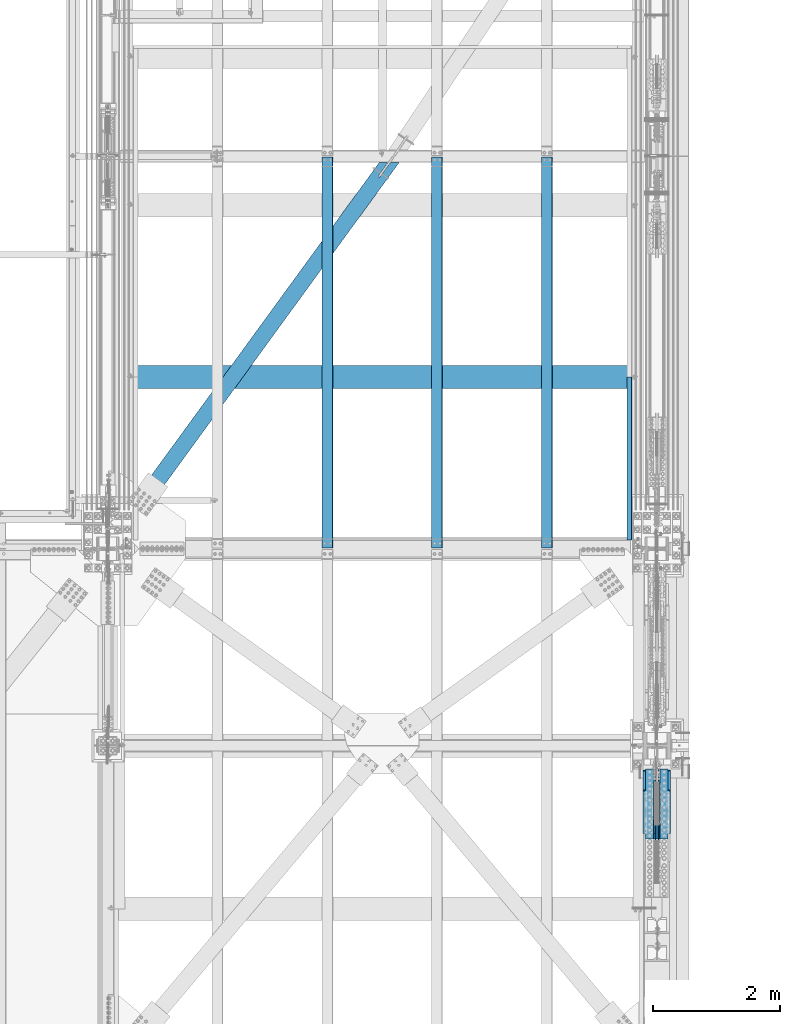
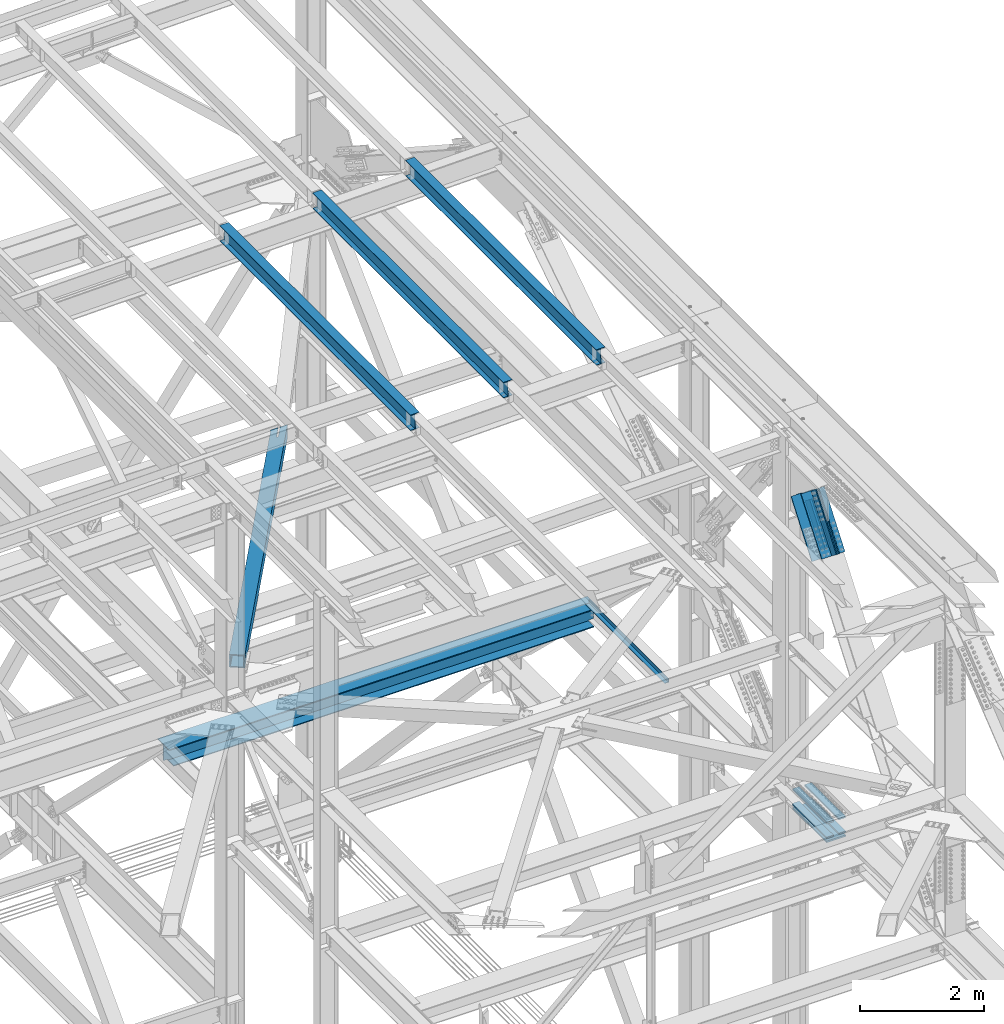
# One storey, part 1989 of 3843: 11 beams, 6 members, 8 elements without a shape of their own.
"""IFC2X3 building model written with IfcOpenShell, lengths in millimetres."""

from ifc_helpers import new_model, si_unit, frame, origin_with_axes, place, context, subcontext, project, spatial, faceted_brep, material, type_object, element, aggregate, save


model = new_model("IFC2X3")

# Units and contexts
model_context = context("Model", 3, precision=1e-05, world=origin_with_axes())
body_context = subcontext(model_context, "Body", "Model", "MODEL_VIEW")
ifc_project = project(units=[si_unit("LENGTHUNIT", "METRE", prefix="MILLI"), si_unit("AREAUNIT", "SQUARE_METRE"), si_unit("VOLUMEUNIT", "CUBIC_METRE"), si_unit("MASSUNIT", "GRAM", prefix="KILO"), si_unit("TIMEUNIT", "SECOND"), si_unit("PLANEANGLEUNIT", "RADIAN"), si_unit("SOLIDANGLEUNIT", "STERADIAN"), si_unit("THERMODYNAMICTEMPERATUREUNIT", "DEGREE_CELSIUS"), si_unit("LUMINOUSINTENSITYUNIT", "LUMEN")], contexts=[model_context])

# Site, building, storey
site_placement = place(None, origin_with_axes())
site = spatial("IfcSite", under=ifc_project, at=site_placement, CompositionType="ELEMENT")
building_placement = place(site_placement, origin_with_axes())
building = spatial("IfcBuilding", under=site, at=building_placement, Name="Undefined", CompositionType="ELEMENT")
storey_placement = place(building_placement, origin_with_axes())
storey = spatial("IfcBuildingStorey", under=building, at=storey_placement, Name="Undefined", CompositionType="ELEMENT", Elevation=0.0)

# Assembly, beam
assembly_1_placement = place(storey_placement, origin_with_axes())
assembly_1 = element("IfcElementAssembly", 1, at=assembly_1_placement, inside=storey, Name="BEAM", AssemblyPlace="NOTDEFINED", PredefinedType="RIGID_FRAME")
ifc_material_1 = material(Name="STEEL/A992")
beam_type_1 = type_object("IfcBeamType", Name="W12X26", PredefinedType="NOTDEFINED")
beam_1_placement = place(assembly_1_placement, frame((80463.9092624381, 92214.7, 46502.5139311718), z_axis=(-0.0211520980073474, 0.0, 0.999776269347241), x_axis=(0.0, 1.0, 0.0)))
beam_1 = element("IfcBeam", 2, at=beam_1_placement, type_object=beam_type_1, material=ifc_material_1, Name="BEAM", ObjectType="W12X26", context=body_context, shape_type="Brep", body=[
    faceted_brep([(12.7000000064072, 82.5500000002939, -155.574999999815), (12.7000000064072, 82.5500000003085, -146.049999999828), (6159.50000000003, 82.5500000003085, -146.049999999836), (6159.50000000003, 82.5500000003085, -155.574999999822), (12.7000000064072, 3.17499999985739, -146.049999999763), (6159.50000000003, 3.17499999985739, -146.049999999777), (12.7000000064072, 3.17500000014843, 146.04999999977), (6159.50000000003, 3.17500000014843, 146.049999999763), (12.7000000064072, 82.5500000005995, 146.049999999697), (6159.50000000003, 82.5500000005995, 146.049999999697), (12.7000000064072, 82.5500000006141, 155.574999999684), (6159.50000000003, 82.5500000005995, 155.574999999677), (12.7000000064072, -82.5500000003231, 155.574999999822), (6159.50000000003, -82.5500000003231, 155.574999999822), (12.7000000064072, -82.5500000003231, 146.049999999836), (6159.50000000003, -82.5500000003231, 146.049999999828), (12.7000000064072, -3.17499999987194, 146.049999999777), (6159.50000000003, -3.17499999987194, 146.049999999763), (12.7000000064072, -3.17500000016298, -146.049999999763), (6159.50000000003, -3.17500000017753, -146.049999999763), (12.7000000064072, -82.5500000006141, -146.04999999969), (6159.50000000003, -82.5500000006286, -146.049999999697), (12.7000000064072, -82.5500000006432, -155.574999999677), (6159.50000000003, -82.5500000006286, -155.574999999677)], [[[0, 1, 2, 3]], [[1, 4, 5, 2]], [[4, 6, 7, 5]], [[6, 8, 9, 7]], [[8, 10, 11, 9]], [[10, 12, 13, 11]], [[12, 14, 15, 13]], [[14, 16, 17, 15]], [[16, 18, 19, 17]], [[18, 20, 21, 19]], [[20, 22, 23, 21]], [[22, 0, 3, 23]], [[5, 7, 9, 11, 13, 15, 17, 19, 21, 23, 3, 2]], [[22, 20, 18, 16, 14, 12, 10, 8, 6, 4, 1, 0]]]),
])
aggregate(assembly_1, [beam_1])

assembly_2_placement = place(storey_placement, origin_with_axes())
assembly_2 = element("IfcElementAssembly", 3, at=assembly_2_placement, inside=storey, Name="BEAM", AssemblyPlace="NOTDEFINED", PredefinedType="RIGID_FRAME")
beam_2_placement = place(assembly_2_placement, frame((83918.3092624381, 92214.7, 46575.5980896944), z_axis=(-0.0211520980073474, 0.0, 0.999776269347241), x_axis=(0.0, 1.0, 0.0)))
beam_2 = element("IfcBeam", 4, at=beam_2_placement, type_object=beam_type_1, material=ifc_material_1, Name="BEAM", ObjectType="W12X26", context=body_context, shape_type="Brep", body=[
    faceted_brep([(12.7000000064072, 82.5500000002939, -155.574999999815), (12.7000000064072, 82.5500000003085, -146.049999999828), (6159.50000000003, 82.5500000003085, -146.049999999836), (6159.50000000003, 82.5500000003085, -155.574999999822), (12.7000000064072, 3.17499999985739, -146.049999999763), (6159.50000000003, 3.17499999985739, -146.049999999777), (12.7000000064072, 3.17500000014843, 146.04999999977), (6159.50000000003, 3.17500000014843, 146.049999999763), (12.7000000064072, 82.5500000005995, 146.049999999697), (6159.50000000003, 82.5500000005995, 146.049999999697), (12.7000000064072, 82.5500000006141, 155.574999999684), (6159.50000000003, 82.5500000005995, 155.574999999677), (12.7000000064072, -82.5500000003231, 155.574999999822), (6159.50000000003, -82.5500000003231, 155.574999999822), (12.7000000064072, -82.5500000003231, 146.049999999836), (6159.50000000003, -82.5500000003231, 146.049999999828), (12.7000000064072, -3.17499999987194, 146.049999999777), (6159.50000000003, -3.17499999987194, 146.049999999763), (12.7000000064072, -3.17500000016298, -146.049999999763), (6159.50000000003, -3.17500000017753, -146.049999999763), (12.7000000064072, -82.5500000006141, -146.04999999969), (6159.50000000003, -82.5500000006286, -146.049999999697), (12.7000000064072, -82.5500000006432, -155.574999999677), (6159.50000000003, -82.5500000006286, -155.574999999677)], [[[0, 1, 2, 3]], [[1, 4, 5, 2]], [[4, 6, 7, 5]], [[6, 8, 9, 7]], [[8, 10, 11, 9]], [[10, 12, 13, 11]], [[12, 14, 15, 13]], [[14, 16, 17, 15]], [[16, 18, 19, 17]], [[18, 20, 21, 19]], [[20, 22, 23, 21]], [[22, 0, 3, 23]], [[5, 7, 9, 11, 13, 15, 17, 19, 21, 23, 3, 2]], [[22, 20, 18, 16, 14, 12, 10, 8, 6, 4, 1, 0]]]),
])
aggregate(assembly_2, [beam_2])

assembly_3_placement = place(storey_placement, origin_with_axes())
assembly_3 = element("IfcElementAssembly", 5, at=assembly_3_placement, inside=storey, Name="BEAM", AssemblyPlace="NOTDEFINED", PredefinedType="RIGID_FRAME")
beam_3_placement = place(assembly_3_placement, frame((82191.1092624381, 92214.7, 46539.0560104331), z_axis=(-0.0211520980073474, 0.0, 0.999776269347241), x_axis=(0.0, 1.0, 0.0)))
beam_3 = element("IfcBeam", 6, at=beam_3_placement, type_object=beam_type_1, material=ifc_material_1, Name="BEAM", ObjectType="W12X26", context=body_context, shape_type="Brep", body=[
    faceted_brep([(12.7000000064072, 82.5500000002939, -155.574999999815), (12.7000000064072, 82.5500000003085, -146.049999999828), (6159.50000000003, 82.5500000003085, -146.049999999836), (6159.50000000003, 82.5500000003085, -155.574999999822), (12.7000000064072, 3.17499999985739, -146.049999999763), (6159.50000000003, 3.17499999985739, -146.049999999777), (12.7000000064072, 3.17500000014843, 146.04999999977), (6159.50000000003, 3.17500000014843, 146.049999999763), (12.7000000064072, 82.5500000005995, 146.049999999697), (6159.50000000003, 82.5500000005995, 146.049999999697), (12.7000000064072, 82.5500000006141, 155.574999999684), (6159.50000000003, 82.5500000005995, 155.574999999677), (12.7000000064072, -82.5500000003231, 155.574999999822), (6159.50000000003, -82.5500000003231, 155.574999999822), (12.7000000064072, -82.5500000003231, 146.049999999836), (6159.50000000003, -82.5500000003231, 146.049999999828), (12.7000000064072, -3.17499999987194, 146.049999999777), (6159.50000000003, -3.17499999987194, 146.049999999763), (12.7000000064072, -3.17500000016298, -146.049999999763), (6159.50000000003, -3.17500000017753, -146.049999999763), (12.7000000064072, -82.5500000006141, -146.04999999969), (6159.50000000003, -82.5500000006286, -146.049999999697), (12.7000000064072, -82.5500000006432, -155.574999999677), (6159.50000000003, -82.5500000006286, -155.574999999677)], [[[0, 1, 2, 3]], [[1, 4, 5, 2]], [[4, 6, 7, 5]], [[6, 8, 9, 7]], [[8, 10, 11, 9]], [[10, 12, 13, 11]], [[12, 14, 15, 13]], [[14, 16, 17, 15]], [[16, 18, 19, 17]], [[18, 20, 21, 19]], [[20, 22, 23, 21]], [[22, 0, 3, 23]], [[5, 7, 9, 11, 13, 15, 17, 19, 21, 23, 3, 2]], [[22, 20, 18, 16, 14, 12, 10, 8, 6, 4, 1, 0]]]),
])
aggregate(assembly_3, [beam_3])

# Assembly, beams
assembly_4_placement = place(storey_placement, origin_with_axes())
assembly_4 = element("IfcElementAssembly", 7, at=assembly_4_placement, inside=storey, Name="COLUMN", AssemblyPlace="NOTDEFINED", PredefinedType="RIGID_FRAME")
ifc_material_2 = material(Name="STEEL/A572-50")
beam_type_2 = type_object("IfcBeamType", PredefinedType="NOTDEFINED")
beam_4_placement = place(assembly_4_placement, frame((85763.1, 87647.3316214822, 39339.1330795921), z_axis=(-1.0, 0.0, 0.0), x_axis=(0.0, 0.999988022812667, -0.00489430599907813)))
beam_4 = element("IfcBeam", 8, at=beam_4_placement, type_object=beam_type_2, material=ifc_material_2, Name="PLATE", context=body_context, shape_type="Brep", body=[
    faceted_brep([(8.73114913702011e-11, 15.8750000000073, -63.5), (8.73114913702011e-11, 15.8750000000073, 63.5), (1104.89999997285, 15.8750000015862, 63.5), (1104.89999997285, 15.8750000015862, -63.5), (-1.01863406598568e-10, -15.8750000000146, 63.5), (1104.89999997268, -15.8749999984284, 63.5), (-1.01863406598568e-10, -15.8750000000146, -63.5), (1104.89999997268, -15.8749999984284, -63.5)], [[[0, 1, 2, 3]], [[1, 4, 5, 2]], [[4, 6, 7, 5]], [[6, 0, 3, 7]], [[5, 7, 3, 2]], [[6, 4, 1, 0]]]),
])
beam_5_placement = place(assembly_4_placement, frame((85763.1, 87648.7454474267, 39628.0011897504), z_axis=(-1.0, 0.0, 0.0), x_axis=(0.0, 0.999988022812667, -0.00489430599907813)))
beam_5 = element("IfcBeam", 9, at=beam_5_placement, type_object=beam_type_2, material=ifc_material_2, Name="PLATE", context=body_context, shape_type="Brep", body=[
    faceted_brep([(8.73114913702011e-11, 15.8750000000073, -63.5), (8.73114913702011e-11, 15.8750000000073, 63.5), (1104.89999997285, 15.8750000015862, 63.5), (1104.89999997285, 15.8750000015862, -63.5), (-1.01863406598568e-10, -15.8750000000146, 63.5), (1104.89999997268, -15.8749999984284, 63.5), (-1.01863406598568e-10, -15.8750000000146, -63.5), (1104.89999997268, -15.8749999984284, -63.5)], [[[0, 1, 2, 3]], [[1, 4, 5, 2]], [[4, 6, 7, 5]], [[6, 0, 3, 7]], [[5, 7, 3, 2]], [[6, 4, 1, 0]]]),
])
beam_6_placement = place(assembly_4_placement, frame((85534.5, 87647.3316214822, 39339.1330795921), z_axis=(-1.0, 0.0, 0.0), x_axis=(0.0, 0.999988022812667, -0.00489430599907813)))
beam_6 = element("IfcBeam", 10, at=beam_6_placement, type_object=beam_type_2, material=ifc_material_2, Name="PLATE", context=body_context, shape_type="Brep", body=[
    faceted_brep([(8.73114913702011e-11, 15.8750000000073, -63.5), (8.73114913702011e-11, 15.8750000000073, 63.5), (1104.89999997285, 15.8750000015862, 63.5), (1104.89999997285, 15.8750000015862, -63.5), (-1.01863406598568e-10, -15.8750000000146, 63.5), (1104.89999997268, -15.8749999984284, 63.5), (-1.01863406598568e-10, -15.8750000000146, -63.5), (1104.89999997268, -15.8749999984284, -63.5)], [[[0, 1, 2, 3]], [[1, 4, 5, 2]], [[4, 6, 7, 5]], [[6, 0, 3, 7]], [[5, 7, 3, 2]], [[6, 4, 1, 0]]]),
])
beam_7_placement = place(assembly_4_placement, frame((85534.5, 87648.7454474267, 39628.0011897504), z_axis=(-1.0, 0.0, 0.0), x_axis=(0.0, 0.999988022812667, -0.00489430599907813)))
beam_7 = element("IfcBeam", 11, at=beam_7_placement, type_object=beam_type_2, material=ifc_material_2, Name="PLATE", context=body_context, shape_type="Brep", body=[
    faceted_brep([(8.73114913702011e-11, 15.8750000000073, -63.5), (8.73114913702011e-11, 15.8750000000073, 63.5), (1104.89999997285, 15.8750000015862, 63.5), (1104.89999997285, 15.8750000015862, -63.5), (-1.01863406598568e-10, -15.8750000000146, 63.5), (1104.89999997268, -15.8749999984284, 63.5), (-1.01863406598568e-10, -15.8750000000146, -63.5), (1104.89999997268, -15.8749999984284, -63.5)], [[[0, 1, 2, 3]], [[1, 4, 5, 2]], [[4, 6, 7, 5]], [[6, 0, 3, 7]], [[5, 7, 3, 2]], [[6, 4, 1, 0]]]),
])
beam_type_3 = type_object("IfcBeamType", PredefinedType="NOTDEFINED")
beam_8_placement = place(assembly_4_placement, frame((85648.8, 88751.8286978822, 39254.3471798376), z_axis=(-1.0, 0.0, 0.0), x_axis=(0.0, -0.999988022812667, 0.00489430599907813)))
beam_8 = element("IfcBeam", 12, at=beam_8_placement, type_object=beam_type_3, material=ifc_material_2, Name="PLATE", context=body_context, shape_type="Brep", body=[
    faceted_brep([(1.45519152283669e-11, 15.8750000000218, -177.800000000003), (1.45519152283669e-11, 15.8750000000218, 177.800000000003), (1104.89999996551, 15.8749999977663, 177.800000000003), (1104.89999996551, 15.8749999977663, -177.800000000003), (-4.36557456851006e-11, -15.8750000000146, 177.800000000003), (1104.89999996545, -15.8750000022774, 177.800000000003), (-4.36557456851006e-11, -15.8750000000146, -177.800000000003), (1104.89999996545, -15.8750000022774, -177.800000000003)], [[[0, 1, 2, 3]], [[1, 4, 5, 2]], [[4, 6, 7, 5]], [[6, 0, 3, 7]], [[5, 7, 3, 2]], [[6, 4, 1, 0]]]),
])
aggregate(assembly_4, [beam_4, beam_5, beam_6, beam_7, beam_8])

# Assembly, beam
assembly_5_placement = place(storey_placement, origin_with_axes())
assembly_5 = element("IfcElementAssembly", 13, at=assembly_5_placement, inside=storey, Name="BENT_PLATE", AssemblyPlace="NOTDEFINED", PredefinedType="RIGID_FRAME")
ifc_material_3 = material(Name="STEEL/A36")
beam_type_4 = type_object("IfcBeamType", PredefinedType="NOTDEFINED")
beam_9_placement = place(assembly_5_placement, frame((85177.3127500011, 93631.939884, 39627.1750000002), z_axis=(0.0, 1.0, 0.0), x_axis=(1.0, 0.0, 0.0)))
beam_9 = element("IfcBeam", 14, at=beam_9_placement, type_object=beam_type_4, material=ifc_material_3, Name="BENT_PLATE", context=body_context, shape_type="Brep", body=[
    faceted_brep([(0.0, 7.27595761418343e-12, 1283.49400000001), (0.0, -3.17500000000291, 1280.31899999999), (69.849999999773, -3.17500000000291, 1280.31899999999), (73.0249999992084, 0.0, 1283.49399999998), (73.0249999992957, -73.0250000004817, 1283.49399999998), (69.8499999998457, -73.0250000002488, 1280.31899999999), (69.849999999773, -3.17500000000291, -1283.49400000001), (0.0, -3.17500000000291, -1283.49400000001), (0.0, 3.17500000000291, -1283.49400000001), (76.1999999997643, 3.17500000000291, -1283.49400000001), (76.1999999998516, -73.0250000002343, -1283.49400000001), (69.8499999998457, -73.0250000002488, -1283.49400000001), (0.0, 3.17500000000291, 1283.49400000001), (76.1999999997643, 3.17500000000291, 1283.49400000001), (76.1999999998516, -73.0250000002343, 1283.49400000001)], [[[0, 1, 2, 3]], [[4, 3, 2, 5]], [[6, 7, 8, 9, 10, 11]], [[8, 12, 13, 9]], [[9, 13, 14, 10]], [[11, 10, 14, 4, 5]], [[6, 11, 5, 2]], [[7, 6, 2, 1]], [[12, 8, 7, 1, 0]], [[14, 13, 12, 0, 3, 4]]]),
])
aggregate(assembly_5, [beam_9])

# Assembly, members
assembly_6_placement = place(storey_placement, origin_with_axes())
assembly_6 = element("IfcElementAssembly", 15, at=assembly_6_placement, inside=storey, Name="V. BRACE", AssemblyPlace="NOTDEFINED", PredefinedType="RIGID_FRAME")
member_type_1 = type_object("IfcMemberType", PredefinedType="NOTDEFINED")
member_1_placement = place(assembly_6_placement, frame((85680.55, 88489.802484789, 45425.1195898453), z_axis=(0.0, 0.796057916025913, -0.605220451019694), x_axis=(0.0, -0.605220451019692, -0.796057916025914)))
member_1 = element("IfcMember", 16, at=member_1_placement, type_object=member_type_1, material=ifc_material_2, Name="PLATE", context=body_context, shape_type="Brep", body=[
    faceted_brep([(1.16415321826935e-10, 19.0500000000029, -95.2500000001601), (-1.16415321826935e-10, 19.0500000000029, 95.2500000001601), (838.200000012905, 19.0500000000029, 95.250000001266), (838.200000013152, 19.0500000000029, -95.249999999076), (-1.16415321826935e-10, -19.0500000000029, 95.2500000001601), (838.200000012905, -19.0500000000029, 95.250000001266), (1.16415321826935e-10, -19.0500000000029, -95.2500000001601), (838.200000013152, -19.0500000000029, -95.249999999076)], [[[0, 1, 2, 3]], [[1, 4, 5, 2]], [[4, 6, 7, 5]], [[6, 0, 3, 7]], [[5, 7, 3, 2]], [[6, 4, 1, 0]]]),
])
member_2_placement = place(assembly_6_placement, frame((85617.05, 88489.802484789, 45425.1195898453), z_axis=(0.0, 0.796057916025913, -0.605220451019694), x_axis=(0.0, -0.605220451019692, -0.796057916025914)))
member_2 = element("IfcMember", 17, at=member_2_placement, type_object=member_type_1, material=ifc_material_2, Name="PLATE", context=body_context, shape_type="Brep", body=[
    faceted_brep([(1.16415321826935e-10, 19.0500000000029, -95.2500000001601), (-1.16415321826935e-10, 19.0500000000029, 95.2500000001601), (838.200000012905, 19.0500000000029, 95.250000001266), (838.200000013152, 19.0500000000029, -95.249999999076), (-1.16415321826935e-10, -19.0500000000029, 95.2500000001601), (838.200000012905, -19.0500000000029, 95.250000001266), (1.16415321826935e-10, -19.0500000000029, -95.2500000001601), (838.200000013152, -19.0500000000029, -95.249999999076)], [[[0, 1, 2, 3]], [[1, 4, 5, 2]], [[4, 6, 7, 5]], [[6, 0, 3, 7]], [[5, 7, 3, 2]], [[6, 4, 1, 0]]]),
])
member_type_2 = type_object("IfcMemberType", Name="L8X8X3/4", PredefinedType="NOTDEFINED")
member_3_placement = place(assembly_6_placement, frame((85763.1, 88803.0371492058, 45354.4890192036), z_axis=(0.0, 0.796057916025913, -0.605220451019694), x_axis=(0.0, -0.605220451019692, -0.796057916025914)))
member_3 = element("IfcMember", 18, at=member_3_placement, type_object=member_type_2, material=ifc_material_2, Name="ANGLE", ObjectType="L8X8X3/4", context=body_context, shape_type="Brep", body=[
    faceted_brep([(2.18278728425503e-10, 101.600000000345, -101.600000000006), (2.18278728425503e-10, 101.600000000345, 101.600000000006), (1104.90000001518, 101.600000000006, 101.599999998441), (1104.90000001537, 101.600000000006, -101.600000001323), (-8.73114913702011e-11, 82.5500000000029, 101.599999999882), (1104.90000001518, 82.5500000000029, 101.599999998441), (7.27595761418343e-11, 82.5500000000029, -82.549999999901), (1104.90000001535, 82.5500000000029, -82.550000001349), (7.27595761418343e-11, -101.600000000006, -82.549999999901), (1104.90000001535, -101.600000000006, -82.550000001349), (-2.25554686039686e-10, -101.600000000329, -101.600000000006), (1104.90000001537, -101.600000000006, -101.600000001323)], [[[0, 1, 2, 3]], [[1, 4, 5, 2]], [[4, 6, 7, 5]], [[6, 8, 9, 7]], [[8, 10, 11, 9]], [[10, 0, 3, 11]], [[5, 7, 9, 11, 3, 2]], [[10, 8, 6, 4, 1, 0]]]),
])
member_4_placement = place(assembly_6_placement, frame((85763.1, 87669.2720383205, 44828.4944152631), z_axis=(0.0, -0.796057916025909, 0.605220451019698), x_axis=(0.0, 0.605220451019692, 0.796057916025914)))
member_4 = element("IfcMember", 19, at=member_4_placement, type_object=member_type_2, material=ifc_material_2, Name="ANGLE", ObjectType="L8X8X3/4", context=body_context, shape_type="Brep", body=[
    faceted_brep([(2.18278728425503e-10, 101.600000000345, -101.600000000006), (2.18278728425503e-10, 101.600000000345, 101.600000000006), (1104.90000001518, 101.600000000006, 101.599999998441), (1104.90000001537, 101.600000000006, -101.600000001323), (-8.73114913702011e-11, 82.5500000000029, 101.599999999882), (1104.90000001518, 82.5500000000029, 101.599999998441), (7.27595761418343e-11, 82.5500000000029, -82.549999999901), (1104.90000001535, 82.5500000000029, -82.550000001349), (7.27595761418343e-11, -101.600000000006, -82.549999999901), (1104.90000001535, -101.600000000006, -82.550000001349), (-2.25554686039686e-10, -101.600000000329, -101.600000000006), (1104.90000001537, -101.600000000006, -101.600000001323)], [[[0, 1, 2, 3]], [[1, 4, 5, 2]], [[4, 6, 7, 5]], [[6, 8, 9, 7]], [[8, 10, 11, 9]], [[10, 0, 3, 11]], [[5, 7, 9, 11, 3, 2]], [[10, 8, 6, 4, 1, 0]]]),
])
member_5_placement = place(assembly_6_placement, frame((85534.5, 88134.3290728672, 44474.924627775), z_axis=(0.0, 0.796057916025913, -0.605220451019694), x_axis=(0.0, 0.605220451019692, 0.796057916025914)))
member_5 = element("IfcMember", 20, at=member_5_placement, type_object=member_type_2, material=ifc_material_2, Name="ANGLE", ObjectType="L8X8X3/4", context=body_context, shape_type="Brep", body=[
    faceted_brep([(2.18278728425503e-10, 101.600000000345, -101.600000000006), (2.18278728425503e-10, 101.600000000345, 101.600000000006), (1104.90000001518, 101.600000000006, 101.599999998441), (1104.90000001537, 101.600000000006, -101.600000001323), (-8.73114913702011e-11, 82.5500000000029, 101.599999999882), (1104.90000001518, 82.5500000000029, 101.599999998441), (7.27595761418343e-11, 82.5500000000029, -82.549999999901), (1104.90000001535, 82.5500000000029, -82.550000001349), (7.27595761418343e-11, -101.600000000006, -82.549999999901), (1104.90000001535, -101.600000000006, -82.550000001349), (-2.25554686039686e-10, -101.600000000329, -101.600000000006), (1104.90000001537, -101.600000000006, -101.600000001323)], [[[0, 1, 2, 3]], [[1, 4, 5, 2]], [[4, 6, 7, 5]], [[6, 8, 9, 7]], [[8, 10, 11, 9]], [[10, 0, 3, 11]], [[5, 7, 9, 11, 3, 2]], [[10, 8, 6, 4, 1, 0]]]),
])
member_6_placement = place(assembly_6_placement, frame((85534.5, 88337.980114659, 45708.0588066917), z_axis=(0.0, -0.796057916025909, 0.605220451019698), x_axis=(0.0, -0.605220451019692, -0.796057916025914)))
member_6 = element("IfcMember", 21, at=member_6_placement, type_object=member_type_2, material=ifc_material_2, Name="ANGLE", ObjectType="L8X8X3/4", context=body_context, shape_type="Brep", body=[
    faceted_brep([(2.18278728425503e-10, 101.600000000345, -101.600000000006), (2.18278728425503e-10, 101.600000000345, 101.600000000006), (1104.90000001518, 101.600000000006, 101.599999998441), (1104.90000001537, 101.600000000006, -101.600000001323), (-8.73114913702011e-11, 82.5500000000029, 101.599999999882), (1104.90000001518, 82.5500000000029, 101.599999998441), (7.27595761418343e-11, 82.5500000000029, -82.549999999901), (1104.90000001535, 82.5500000000029, -82.550000001349), (7.27595761418343e-11, -101.600000000006, -82.549999999901), (1104.90000001535, -101.600000000006, -82.550000001349), (-2.25554686039686e-10, -101.600000000329, -101.600000000006), (1104.90000001537, -101.600000000006, -101.600000001323)], [[[0, 1, 2, 3]], [[1, 4, 5, 2]], [[4, 6, 7, 5]], [[6, 8, 9, 7]], [[8, 10, 11, 9]], [[10, 0, 3, 11]], [[5, 7, 9, 11, 3, 2]], [[10, 8, 6, 4, 1, 0]]]),
])
aggregate(assembly_6, [member_1, member_3, member_4, member_5, member_6, member_2])

# Assembly, beam
assembly_7_placement = place(storey_placement, origin_with_axes())
assembly_7 = element("IfcElementAssembly", 22, at=assembly_7_placement, inside=storey, AssemblyPlace="NOTDEFINED", PredefinedType="RIGID_FRAME")
ifc_material_4 = material()
beam_type_5 = type_object("IfcBeamType", Name="HSS10X10X3/4", PredefinedType="NOTDEFINED")
beam_10_placement = place(assembly_7_placement, frame((77012.8, 92214.7, 42246.55), z_axis=(-0.808304339418129, 0.588764889304569, 0.0), x_axis=(0.588764889304577, 0.808304339418123, 0.0)))
beam_10 = element("IfcBeam", 23, at=beam_10_placement, type_object=beam_type_5, material=ifc_material_4, ObjectType="HSS10X10X3/4", context=body_context, shape_type="Brep", body=[
    faceted_brep([(7503.81122385527, -127.0, 14.2872405404714), (7251.39872425108, -127.0, 14.2872405424141), (7251.39872425108, -107.949999999997, 14.2872405424141), (7503.81122385527, -107.949999999997, 14.2872405404714), (7245.93113456514, -127.0, 13.1996693341725), (7245.93113456514, -107.949999999997, 13.1996693341725), (7241.29593584506, -127.0, 10.1025285669466), (7241.29593584506, -107.949999999997, 10.1025285669466), (7238.19879507777, -127.0, 5.4673298468997), (7238.19879507777, -107.949999999997, 5.4673298468997), (7237.11122386946, -127.0, -0.000259839011960139), (7237.11122386946, -107.949999999997, -0.000259839011960139), (7238.19879507771, -127.0, -5.46784876505171), (7238.19879507771, -107.949999999997, -5.46784876505171), (7241.29593584492, -127.0, -10.1030474851423), (7241.29593584492, -107.949999999997, -10.1030474851423), (7245.93113456495, -127.0, -13.2001882524191), (7245.93113456495, -107.949999999997, -13.2001882524191), (7251.39872425086, -127.0, -14.287759460748), (7251.39872425086, -107.949999999997, -14.287759460748), (7524.62511274999, -127.0, -14.2877594627416), (7524.62511274999, -107.949999999997, -14.2877594627416), (7503.81122385527, 107.949999999997, 14.2872405404714), (7251.39872425108, 107.949999999997, 14.2872405424141), (7251.39872425108, 127.0, 14.2872405424141), (7503.81122385527, 127.0, 14.2872405404714), (7245.93113456514, 107.949999999997, 13.1996693341725), (7245.93113456514, 127.0, 13.1996693341725), (7241.29593584506, 107.949999999997, 10.1025285669466), (7241.29593584506, 127.0, 10.1025285669466), (7238.19879507777, 107.949999999997, 5.4673298468997), (7238.19879507777, 127.0, 5.4673298468997), (7237.11122386946, 107.949999999997, -0.000259839011960139), (7237.11122386946, 127.0, -0.000259839011960139), (7238.19879507771, 107.949999999997, -5.46784876505171), (7238.19879507771, 127.0, -5.46784876505171), (7241.29593584492, 107.949999999997, -10.1030474851423), (7241.29593584492, 127.0, -10.1030474851423), (7245.93113456495, 107.949999999997, -13.2001882524191), (7245.93113456495, 127.0, -13.2001882524191), (7251.39872425086, 107.949999999997, -14.287759460748), (7251.39872425086, 127.0, -14.287759460748), (7524.62511274999, 107.949999999997, -14.2877594627416), (7524.62511274999, 127.0, -14.2877594627416), (7606.72415220956, 127.0, -127.000000057821), (1089.78176046631, 127.0, -127.000000008388), (1089.7817604663, 127.0, 126.999999991859), (7421.71180649831, 127.0, 126.999999943831), (7435.58773242665, -107.949999999997, 107.949999943711), (7435.58773242665, 107.949999999997, 107.949999943711), (7421.71180649831, -127.0, 126.999999943831), (7592.84822628122, -107.949999999997, -107.950000057702), (1089.78176046631, -107.949999999997, -107.950000008371), (1089.78176046631, -107.949999999997, 107.949999991856), (1089.78176046631, 1.58750000000146, -107.950000008371), (1089.78176046631, 1.58750000000146, -127.000000008388), (1342.19426008538, 1.58750000000146, -127.000000010295), (1342.19426008551, 1.58750000000146, -107.95000001027), (1347.66184977128, 0.499928791716229, -127.000000010346), (1347.66184977142, 0.499928791716229, -107.950000010328), (1352.29704849134, -2.59721197552426, -127.000000010367), (1352.29704849148, -2.59721197552426, -107.95000001035), (1355.3941892586, -7.23241069557116, -127.000000010396), (1355.39418925875, -7.23241069557116, -107.950000010379), (1352.29704849148, -22.8027880244699, -107.95000001035), (1347.66184977142, -25.8999287917104, -107.950000010328), (1342.19426008551, -26.9874999999956, -107.95000001027), (1089.78176046631, -26.9874999999956, -107.950000008371), (7592.84822628122, 107.949999999997, -107.950000057702), (1089.78176046631, 107.949999999997, -107.950000008371), (1356.48176046702, -12.6999996185259, -107.950000010394), (1355.39418925875, -18.167589304423, -107.950000010379), (1089.78176046631, 107.949999999997, 107.949999991856), (1089.78176046631, 1.58750000000146, 107.949999991856), (1089.7817604663, 1.58750000000146, 126.999999991859), (1342.19426008716, 1.58750000000146, 107.949999989935), (1342.1942600873, 1.58750000000146, 126.999999989953), (1347.66184977308, 0.499928791716229, 107.949999989899), (1347.6618497732, 0.499928791716229, 126.999999989909), (1352.29704849311, -2.59721197552426, 107.949999989855), (1352.29704849327, -2.59721197552426, 126.99999998988), (1355.39418926038, -7.23241069557116, 107.949999989826), (1355.39418926052, -7.23241069557116, 126.999999989851), (1352.29704849327, -22.8027880244699, 126.99999998988), (1347.6618497732, -25.8999287917104, 126.999999989909), (1342.1942600873, -26.9874999999956, 126.999999989953), (1089.7817604663, -26.9874999999956, 126.999999991859), (1089.7817604663, -127.0, 126.999999991859), (1356.4817604688, -12.6999996185259, 126.999999989851), (1355.39418926052, -18.167589304423, 126.999999989851), (1347.66184977308, -25.8999287917104, 107.949999989899), (1342.19426008716, -26.9874999999956, 107.949999989935), (1352.29704849311, -22.8027880244699, 107.949999989855), (1355.39418926038, -18.167589304423, 107.949999989826), (1356.48176046867, -12.6999996185259, 107.949999989819), (1089.78176046631, -26.9874999999956, 107.949999991856), (1089.78176046631, -26.9874999999956, -127.000000008388), (1089.78176046631, -127.0, -127.000000008388), (1342.19426008538, -26.9874999999956, -127.000000010295), (1347.66184977128, -25.8999287917104, -127.000000010346), (1352.29704849134, -22.8027880244699, -127.000000010367), (1355.3941892586, -18.167589304423, -127.000000010396), (1356.48176046688, -12.6999996185259, -127.000000010404), (7606.72415220956, -127.0, -127.000000057821)], [[[0, 1, 2, 3]], [[4, 5, 2, 1]], [[6, 7, 5, 4]], [[8, 9, 7, 6]], [[10, 11, 9, 8]], [[12, 13, 11, 10]], [[14, 15, 13, 12]], [[16, 17, 15, 14]], [[18, 19, 17, 16]], [[20, 21, 19, 18]], [[22, 23, 24, 25]], [[26, 27, 24, 23]], [[28, 29, 27, 26]], [[30, 31, 29, 28]], [[32, 33, 31, 30]], [[34, 35, 33, 32]], [[36, 37, 35, 34]], [[38, 39, 37, 36]], [[40, 41, 39, 38]], [[42, 43, 41, 40]], [[44, 45, 46, 47, 25, 24, 27, 29, 31, 33, 35, 37, 39, 41, 43]], [[48, 49, 22, 25, 47, 50, 0, 3]], [[51, 52, 53, 48, 3, 2, 5, 7, 9, 11, 13, 15, 17, 19, 21]], [[54, 55, 56, 57]], [[57, 56, 58, 59]], [[59, 58, 60, 61]], [[61, 60, 62, 63]], [[64, 65, 66, 67, 52, 51, 68, 69, 54, 57, 59, 61, 63, 70, 71]], [[38, 36, 34, 32, 30, 28, 26, 23, 22, 49, 72, 69, 68, 42, 40]], [[46, 45, 55, 54, 69, 72, 73, 74]], [[74, 73, 75, 76]], [[76, 75, 77, 78]], [[78, 77, 79, 80]], [[80, 79, 81, 82]], [[83, 84, 85, 86, 87, 50, 47, 46, 74, 76, 78, 80, 82, 88, 89]], [[84, 90, 91, 85]], [[83, 92, 90, 84]], [[89, 93, 92, 83]], [[88, 94, 93, 89]], [[82, 81, 94, 88]], [[79, 77, 75, 73, 72, 49, 48, 53, 95, 91, 90, 92, 93, 94, 81]], [[85, 91, 95, 86]], [[53, 52, 67, 96, 97, 87, 86, 95]], [[66, 98, 96, 67]], [[65, 99, 98, 66]], [[64, 100, 99, 65]], [[71, 101, 100, 64]], [[70, 102, 101, 71]], [[63, 62, 102, 70]], [[60, 58, 56, 55, 45, 44, 103, 97, 96, 98, 99, 100, 101, 102, 62]], [[16, 14, 12, 10, 8, 6, 4, 1, 0, 50, 87, 97, 103, 20, 18]], [[103, 44, 43, 42, 68, 51, 21, 20]]]),
])
aggregate(assembly_7, [beam_10])

assembly_8_placement = place(storey_placement, origin_with_axes())
assembly_8 = element("IfcElementAssembly", 24, at=assembly_8_placement, inside=storey, Name="BEAM", AssemblyPlace="NOTDEFINED", PredefinedType="RIGID_FRAME")
beam_type_6 = type_object("IfcBeamType", Name="W14X90", PredefinedType="NOTDEFINED")
beam_11_placement = place(assembly_8_placement, frame((77317.6, 94915.831258, 39446.2), z_axis=(0.0, 0.0, 1.0), x_axis=(1.0, 0.0, 0.0)))
beam_11 = element("IfcBeam", 25, at=beam_11_placement, type_object=beam_type_6, material=ifc_material_1, Name="BEAM", ObjectType="W14X90", context=body_context, shape_type="Brep", body=[
    faceted_brep([(18.2562499999913, -5.55625000000146, -146.050000000003), (18.2562499999913, 5.55625000000146, -146.050000000003), (94.4562501907058, 5.55625000000146, -146.050000000003), (94.4562501907058, -5.55625000000146, -146.050000000003), (99.3163297087449, 5.55625000000146, -147.016729922594), (99.3163297087449, -5.55625000000146, -147.016729922594), (103.436506176906, 5.55625000000146, -149.769743823068), (103.436506176906, -5.55625000000146, -149.769743823068), (106.189520077387, 5.55625000000146, -153.889920291222), (106.189520077387, -5.55625000000146, -153.889920291222), (107.156249999971, -5.55625000000146, -158.749999809268), (107.156249999971, 5.55625000000146, -158.749999809268), (107.156249999971, 5.55625000000146, -160.337500000001), (107.156249999971, 184.150000000001, -160.337500000001), (107.156249999971, 184.150000000001, -177.800000000003), (107.156249999971, -184.150000000001, -177.800000000003), (107.156249999971, -184.150000000001, -160.337500000001), (107.156249999971, -5.55625000000146, -160.337500000001), (18.2562499999913, 5.55625000000146, 160.337500000001), (18.2562499999913, 184.150000000001, 160.337500000001), (8008.14375000002, 184.150000000001, 160.337500000001), (8008.14375000002, 5.55625000000146, 160.337500000001), (18.2562499999913, 184.150000000001, 177.800000000003), (8008.14375000002, 184.150000000001, 177.800000000003), (18.2562499999913, -184.150000000001, 177.800000000003), (8008.14375000002, -184.150000000001, 177.800000000003), (18.2562499999913, -184.150000000001, 160.337500000001), (8008.14375000002, -184.150000000001, 160.337500000001), (18.2562499999913, -5.55625000000146, 160.337500000001), (8008.14375000002, -5.55625000000146, 160.337500000001), (8008.14375000002, 5.55625000000146, -103.599999999999), (8008.14375000002, 5.55625000000146, 127.0), (8008.14375000002, -5.55625000000146, -146.050000000003), (8008.14375000002, 5.55625000000146, -146.050000000003), (7931.94374980927, -5.55625000000146, -146.050000000003), (7931.94374980927, 5.55625000000146, -146.050000000003), (7927.08367029123, -5.55625000000146, -147.016729922594), (7927.08367029123, 5.55625000000146, -147.016729922594), (7922.96349382307, -5.55625000000146, -149.769743823068), (7922.96349382307, 5.55625000000146, -149.769743823068), (7920.21047992259, -5.55625000000146, -153.889920291222), (7920.21047992259, 5.55625000000146, -153.889920291222), (7919.24375000001, -5.55625000000146, -158.749999809268), (7919.24375000001, 5.55625000000146, -158.749999809268), (7919.24375000001, -5.55625000000146, -160.337500000001), (7919.24375000001, -184.150000000001, -160.337500000001), (7919.24375000001, -184.150000000001, -177.800000000003), (7919.24375000001, 184.150000000001, -177.800000000003), (7919.24375000001, 184.150000000001, -160.337500000001), (7919.24375000001, 5.55625000000146, -160.337500000001), (18.2562499999913, 5.55625000000146, -103.599999999999), (18.2562499999913, 5.55625000000146, 127.0)], [[[0, 1, 2, 3]], [[3, 2, 4, 5]], [[5, 4, 6, 7]], [[7, 6, 8, 9]], [[10, 11, 12, 13, 14, 15, 16, 17]], [[9, 8, 11, 10]], [[18, 19, 20, 21]], [[19, 22, 23, 20]], [[22, 24, 25, 23]], [[24, 26, 27, 25]], [[26, 28, 29, 27]], [[30, 31, 21, 20, 23, 25, 27, 29, 32, 33]], [[32, 34, 35, 33]], [[36, 37, 35, 34]], [[38, 39, 37, 36]], [[40, 41, 39, 38]], [[42, 43, 41, 40]], [[44, 45, 46, 47, 48, 49, 43, 42]], [[17, 16, 45, 44]], [[16, 15, 46, 45]], [[15, 14, 47, 46]], [[14, 13, 48, 47]], [[13, 12, 49, 48]], [[37, 39, 41, 43, 49, 12, 11, 8, 6, 4, 2, 1, 50, 51, 18, 21, 31, 30, 33, 35]], [[28, 26, 24, 22, 19, 18, 51, 50, 1, 0]], [[29, 28, 0, 3, 5, 7, 9, 10, 17, 44, 42, 40, 38, 36, 34, 32]]]),
])
aggregate(assembly_8, [beam_11])

save(model, "model.ifc")
